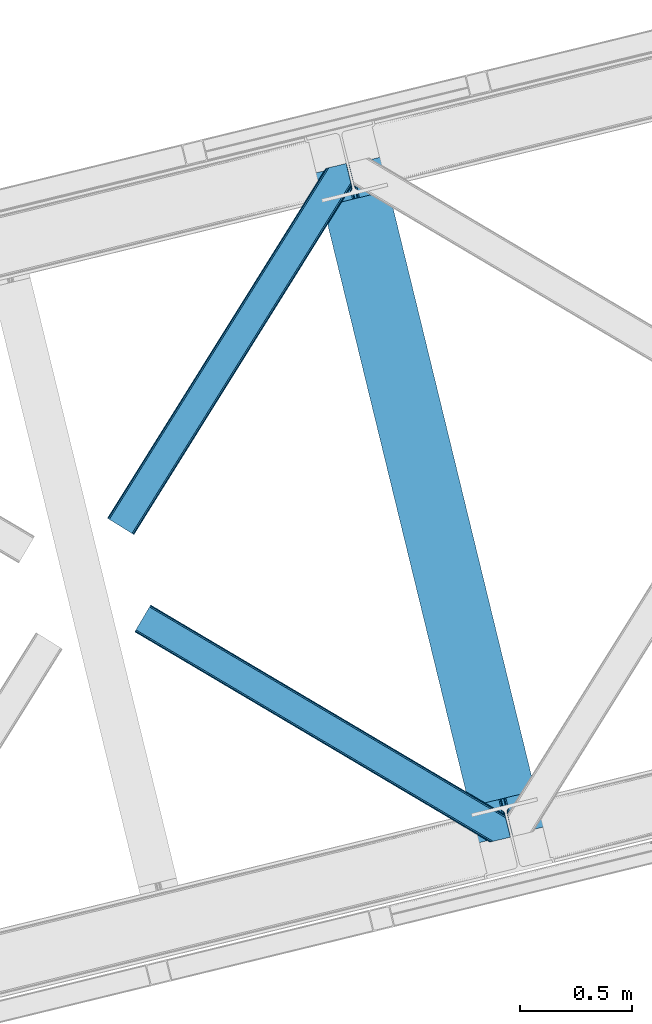
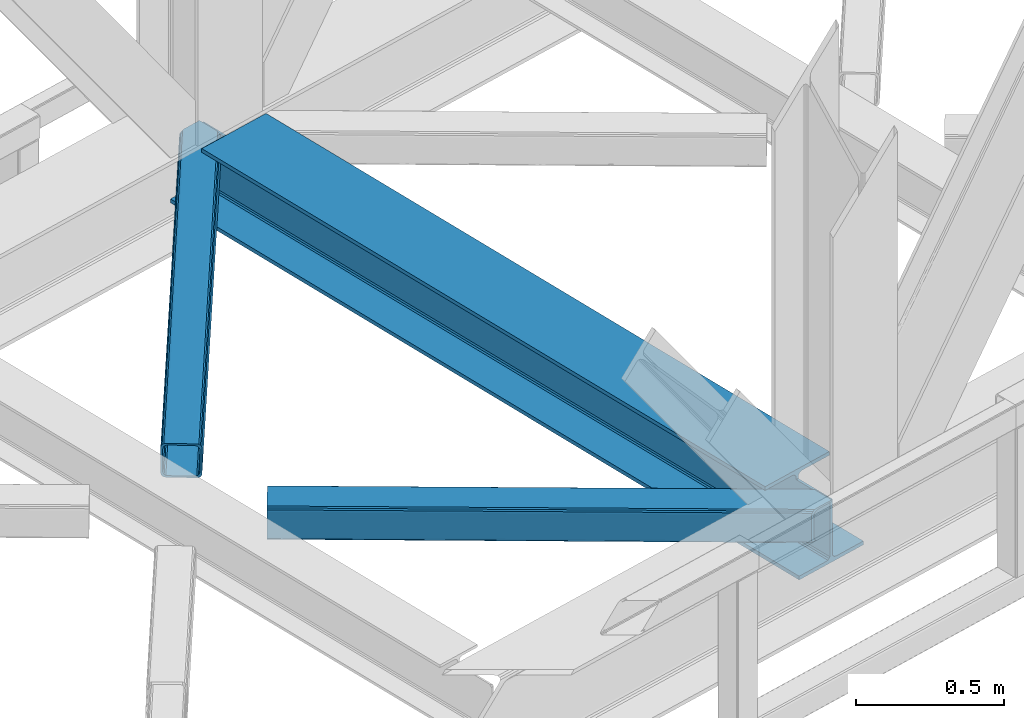
# One storey, part 67 of 92: 2 members, 1 beam.
"""IFC4 building model written with IfcOpenShell, lengths in millimetres."""

from ifc_helpers import new_model, entity, si_unit, converted_unit, derived_unit, direction, frame, origin, place, context, subcontext, project, spatial, triangles, polygons, material, type_object, element, save


model = new_model("IFC4")

# Units and contexts
model_context = context("Model", 3, precision=0.01, world=origin(), true_north=direction((6.12303176911189e-17, 1.0)))
plan_context = context("Plan", 3, precision=0.01, world=origin(), true_north=direction((6.12303176911189e-17, 1.0)))
body_context = subcontext(model_context, "Body", "Model", "MODEL_VIEW")
ifc_project = project(units=[si_unit("LENGTHUNIT", "METRE", prefix="MILLI"), si_unit("AREAUNIT", "SQUARE_METRE"), si_unit("VOLUMEUNIT", "CUBIC_METRE"), converted_unit("PLANEANGLEUNIT", "DEGREE", entity("IfcRatioMeasure", 0.0174532925199433), si_unit("PLANEANGLEUNIT", "RADIAN"), dimensions=[0, 0, 0, 0, 0, 0, 0]), si_unit("MASSUNIT", "GRAM", prefix="KILO"), derived_unit("MASSDENSITYUNIT", [(si_unit("MASSUNIT", "GRAM", prefix="KILO"), 1), (si_unit("LENGTHUNIT", "METRE"), -3)]), derived_unit("MOMENTOFINERTIAUNIT", [(si_unit("LENGTHUNIT", "METRE"), 4)]), si_unit("TIMEUNIT", "SECOND"), si_unit("FREQUENCYUNIT", "HERTZ"), si_unit("THERMODYNAMICTEMPERATUREUNIT", "DEGREE_CELSIUS"), derived_unit("THERMALTRANSMITTANCEUNIT", [(si_unit("MASSUNIT", "GRAM", prefix="KILO"), 1), (si_unit("THERMODYNAMICTEMPERATUREUNIT", "KELVIN"), -1), (si_unit("TIMEUNIT", "SECOND"), -3)]), derived_unit("VOLUMETRICFLOWRATEUNIT", [(si_unit("LENGTHUNIT", "METRE"), 3), (si_unit("TIMEUNIT", "SECOND"), -1)]), derived_unit("MASSFLOWRATEUNIT", [(si_unit("MASSUNIT", "GRAM", prefix="KILO"), 1), (si_unit("TIMEUNIT", "SECOND"), -1)]), derived_unit("ROTATIONALFREQUENCYUNIT", [(si_unit("TIMEUNIT", "SECOND"), -1)]), si_unit("ELECTRICCURRENTUNIT", "AMPERE"), si_unit("ELECTRICVOLTAGEUNIT", "VOLT"), si_unit("POWERUNIT", "WATT"), si_unit("FORCEUNIT", "NEWTON", prefix="KILO"), si_unit("ILLUMINANCEUNIT", "LUX"), si_unit("LUMINOUSFLUXUNIT", "LUMEN"), si_unit("LUMINOUSINTENSITYUNIT", "CANDELA"), derived_unit("USERDEFINED", [(si_unit("MASSUNIT", "GRAM", prefix="KILO"), -1), (si_unit("LENGTHUNIT", "METRE"), -2), (si_unit("TIMEUNIT", "SECOND"), 3), (si_unit("LUMINOUSFLUXUNIT", "LUMEN"), 1)]), derived_unit("LINEARVELOCITYUNIT", [(si_unit("LENGTHUNIT", "METRE"), 1), (si_unit("TIMEUNIT", "SECOND"), -1)]), si_unit("PRESSUREUNIT", "PASCAL"), derived_unit("USERDEFINED", [(si_unit("LENGTHUNIT", "METRE"), -2), (si_unit("MASSUNIT", "GRAM", prefix="KILO"), 1), (si_unit("TIMEUNIT", "SECOND"), -2)]), derived_unit("LINEARFORCEUNIT", [(si_unit("MASSUNIT", "GRAM", prefix="KILO"), 1), (si_unit("LENGTHUNIT", "METRE"), 1), (si_unit("TIMEUNIT", "SECOND"), -2), (si_unit("LENGTHUNIT", "METRE"), -1)]), derived_unit("PLANARFORCEUNIT", [(si_unit("MASSUNIT", "GRAM", prefix="KILO"), 1), (si_unit("LENGTHUNIT", "METRE"), 1), (si_unit("TIMEUNIT", "SECOND"), -2), (si_unit("LENGTHUNIT", "METRE"), -2)])], contexts=[model_context, plan_context])

# Site, building, storey
site_placement = place(None, origin())
site = spatial("IfcSite", under=ifc_project, at=site_placement, CompositionType="ELEMENT")
building_placement = place(site_placement, origin())
building = spatial("IfcBuilding", under=site, at=building_placement, CompositionType="ELEMENT")
storey_placement = place(building_placement, frame((0.0, 0.0, 15900.0)))
storey = spatial("IfcBuildingStorey", under=building, at=storey_placement, Name="05", CompositionType="ELEMENT", Elevation=15900.0)

# Beam
ifc_material = material(Name="Metal painted (White)")
beam_type = type_object("IfcBeamType", PredefinedType="BEAM")
beam_placement = place(storey_placement, frame((-18024.61, 13401.24, 3385.0)))
element("IfcBeam", 1, at=beam_placement, inside=storey, type_object=beam_type, material=ifc_material, ObjectType="Steel Beam", PredefinedType="BEAM", context=body_context, shape_type="Tessellation", body=[
    polygons([(1018.1664837833, 71.0478278971021, 15.4999999999986), (1018.1664837833, 71.0478278971021, 0.0), (291.465617442448, 3052.25531830422, 0.0), (291.465617442448, 3052.25531830422, 15.4999999999986), (894.779372399336, 40.9709140873291, 15.4999999999986), (168.078506058485, 3022.17840449444, 15.4999999999986), (888.087028625368, 39.3395844888221, 16.8701684148006), (161.38616228452, 3020.54707489593, 16.8701684148006), (882.413533524757, 37.956610033654, 20.7720779386413), (155.712667183904, 3019.16410044077, 20.7720779386413), (878.622625296178, 37.0325360459162, 26.6116982174316), (151.921758955327, 3018.24002645303, 26.6116982174316), (877.291435352781, 36.7080444135007, 33.500000000001), (150.59056901193, 3017.91553482062, 33.500000000001), (140.875048430516, 3015.54727389071, 33.500000000001), (140.875048430516, 3015.54727389071, 259.000000000002), (150.59056901193, 3017.91553482062, 259.000000000002), (8.66293703438714e-12, 2981.20749040711, 0.0), (6.49720277579036e-12, 2981.20749040711, 15.4999999999986), (123.38711138397, 3011.28440421689, 15.4999999999986), (130.079455157935, 3012.91573381539, 16.8701684147963), (135.752950258553, 3014.29870827056, 20.7720779386413), (139.543858487119, 3015.22278225829, 26.6116982174294), (877.291435352781, 36.7080444135007, 259.000000000002), (867.575914771367, 34.3397834835992, 259.000000000002), (867.575914771369, 34.3397834835992, 33.500000000001), (866.24472482797, 34.0152918511837, 26.6116982174294), (862.453816599404, 33.0912178634546, 20.7720779386413), (856.780321498788, 31.7082434082822, 16.8701684147963), (850.087977724821, 30.0769138097752, 15.4999999999986), (726.700866340857, 0.0, 15.4999999999986), (726.700866340857, 0.0, 0.0), (838.124523615912, 197.385937999183, 259.069791973884), (186.469722099971, 2870.72539801219, 259.000000000002), (186.693115201822, 2869.80895360721, 259.61730333112), (186.705504045448, 2869.75812937344, 266.500003008253), (837.979344808145, 197.981416001708, 266.500002998871), (837.979694928899, 197.979979696973, 260.000004007589), (828.499586345876, 194.645865944434, 259.006343171919), (828.276216326111, 195.562317481914, 259.61730333112), (828.263827482484, 195.613141715689, 266.500003008253), (176.989986719784, 2867.38985508742, 266.500002998871), (176.989636599034, 2867.39129139215, 260.000004007589), (176.844830940692, 2867.98534020594, 259.07612046749), (176.754201518561, 2868.35713708228, 259.000000000002), (839.310832678068, 198.304685446393, 273.388305639783), (843.10110926677, 199.231350618306, 279.227924098781), (848.774180214294, 200.616065081981, 283.12983240061), (855.46637189544, 202.248018612798, 284.500000377228), (978.853400583278, 232.325271667905, 284.500000138971), (978.851730776626, 232.332121736639, 299.999995328161), (687.386308679356, 161.283492472598, 299.999995890962), (687.387978486005, 161.276642403863, 284.500000701776), (810.775007173849, 191.353895458974, 284.500000463519), (817.467494070001, 192.984637925557, 283.129832461069), (823.141405718761, 194.365903570083, 279.227924137322), (826.93294050574, 195.287407219375, 273.388305663684), (175.658498849859, 2867.06658564273, 273.388305639788), (171.868222261176, 2866.13992047082, 279.227924098781), (166.195151313642, 2864.75520600715, 283.129832400619), (159.502959632499, 2863.12325247633, 284.500000377228), (36.115930944662, 2833.04599942122, 284.500000138971), (36.1176007513137, 2833.03914935249, 299.999995328161), (327.583022848584, 2904.08777861653, 299.999995890962), (327.581353041935, 2904.09462868526, 284.500000701776), (204.19432435409, 2874.01737563015, 284.500000463519), (197.501837457939, 2872.38663316357, 283.12983246106), (191.827925809187, 2871.00536751904, 279.227924137322), (188.036391022187, 2870.08386386975, 273.388305663684)], [[[1, 2, 3, 4]], [[5, 1, 4, 6]], [[7, 5, 6, 8]], [[9, 7, 8, 10]], [[11, 9, 10, 12]], [[13, 11, 12, 14]], [[15, 16, 17, 14, 12, 10, 8, 6, 4, 3, 18, 19, 20, 21, 22, 23]], [[13, 24, 25, 26, 27, 28, 29, 30, 31, 32, 2, 1, 5, 7, 9, 11]], [[2, 32, 18, 3]], [[32, 31, 19, 18]], [[31, 30, 20, 19]], [[27, 26, 15, 23]], [[28, 27, 23, 22]], [[29, 28, 22, 21]], [[30, 29, 21, 20]], [[33, 24, 13, 14, 17, 34, 35, 36, 37, 38]], [[25, 39, 40, 41, 42, 43, 44, 16, 15, 26]], [[39, 25, 24, 33]], [[45, 34, 17, 16]], [[41, 40, 38, 37, 46, 47, 48, 49, 50, 51, 52, 53, 54, 55, 56, 57]], [[42, 58, 59, 60, 61, 62, 63, 64, 65, 66, 67, 68, 69, 36, 35, 43]], [[46, 37, 36, 69]], [[47, 46, 69, 68]], [[48, 47, 68, 67]], [[49, 48, 67, 66]], [[50, 49, 66, 65]], [[51, 50, 65, 64]], [[52, 51, 64, 63]], [[53, 52, 63, 62]], [[54, 53, 62, 61]], [[55, 54, 61, 60]], [[56, 55, 60, 59]], [[57, 56, 59, 58]], [[41, 57, 58, 42]]], closed=False),
])

# Members
member_type_1 = type_object("IfcMemberType", PredefinedType="BRACE")
member_1_placement = place(storey_placement, frame((-18949.85, 14772.6, 3510.0)))
element("IfcMember", 2, at=member_1_placement, inside=storey, type_object=member_type_1, ObjectType="Steel Horizontal Brace", PredefinedType="BRACE", context=body_context, shape_type="Tessellation", body=[
    triangles([(933.016305541994, 1535.69114685059, 0.0), (967.77581176758, 1393.09054870606, 0.0), (14.8444427490249, 64.8692962646492, 0.0), (103.913424682618, 9.26687622070313, 0.0), (928.799121093751, 1552.99009094238, 5.49966430664063), (928.938647460938, 1552.41570739746, 5.20782165527635), (930.798999023438, 1544.78594055176, 1.33247680664135), (971.99299621582, 1375.79160461426, 5.49966430664063), (971.852307128906, 1376.36715087891, 5.20782165527635), (969.993118286133, 1383.99575500488, 1.33247680664135), (972.208099365234, 1375.53813171387, 5.85313110351854), (972.418551635743, 1375.28233337402, 6.20659790039281), (928.911904907229, 1553.56912536621, 5.74383544921875), (972.720858764649, 1375.53696899414, 6.35310058594041), (929.027014160158, 1554.17606506348, 5.9996337890625), (973.022003173828, 1375.79160461426, 6.49960327148438), (929.142123413087, 1554.78300476074, 6.25659484863354), (929.250256347656, 1555.36203918457, 6.49960327148438), (4.34740905761646, 71.4223846435561, 5.12526855468968), (1.13016357422021, 73.4315643310547, 10.8028289794929), (973.355703735353, 1630.84231567383, 10.8028289794929), (976.91130065918, 1631.70854187012, 6.49960327148438), (9.16455688476708, 68.4167541503921, 1.33247680664135), (971.503491210937, 1630.3900177002, 17.5000946044929), (0.0, 74.1373352050796, 17.5000946044929), (1081.09680175781, 1548.91592102051, 6.49960327148438), (1056.20297241211, 1651.03759460449, 6.49960327148438), (971.503491210937, 1630.3900177002, 122.500662231447), (0.0, 74.1373352050796, 122.500662231447), (973.355703735353, 1630.84231567383, 129.197927856447), (1.13016357422021, 73.4315643310547, 129.197927856447), (978.633288574219, 1632.12828369141, 134.874325561526), (4.34740905761646, 71.4223846435561, 134.874325561526), (986.526992797852, 1634.05258483887, 138.667117309571), (9.16455688476708, 68.4167541503921, 138.667117309571), (995.835726928712, 1636.32221374512, 139.999594116212), (14.8444427490249, 64.8692962646492, 139.999594116212), (118.757867431643, 0.0, 17.5000946044929), (117.62886657715, 0.705770874024893, 10.8028289794929), (1085.13725280762, 1551.24949951172, 10.9783996582046), (1087.41153259277, 1552.56337280274, 13.5003387451179), (109.594473266603, 5.7205810546875, 1.33247680664135), (114.410458374023, 2.71495056152344, 5.12526855468968), (1087.56501159668, 1551.93434143066, 17.5000946044929), (1081.77234191895, 1575.70149536133, 139.999594116212), (1063.00372009277, 1652.69447021484, 139.999594116212), (103.913424682618, 9.26687622070313, 139.999594116212), (1083.9896484375, 1566.60553894043, 138.667117309571), (109.594473266603, 5.7205810546875, 138.667117309571), (1085.86860351562, 1558.8955444336, 134.874325561526), (114.410458374023, 2.71495056152344, 134.874325561526), (1087.12434082031, 1553.7435333252, 129.197927856447), (117.62886657715, 0.705770874024893, 129.197927856447), (1087.56501159668, 1551.93434143066, 122.500662231447), (118.757867431643, 0.0, 122.500662231447), (1082.5362487793, 1566.77297058106, 12.1260040283232), (1083.96058044434, 1566.72297363281, 13.5003387451179), (1077.84700012207, 1569.98440246582, 8.3320495605476), (1074.64603271485, 1577.50138549805, 6.99957275390625), (1056.69131469727, 1651.1561920166, 6.99957275390625), (1005.56885375977, 1638.69416198731, 6.99957275390625), (20.7789642333992, 61.1625457763676, 6.99957275390625), (97.9742523193381, 12.9736267089847, 6.99957275390625), (108.471286010743, 6.42053833007958, 12.1260040283232), (111.689694213866, 4.41252136230469, 17.8035644531265), (1084.80704040527, 1563.24992980957, 17.8035644531265), (103.65530090332, 9.42733154296911, 8.3320495605476), (1085.24771118164, 1561.44073791504, 24.4996673583992), (112.818695068359, 3.70675048828161, 24.4996673583992), (983.088830566408, 1633.21426391602, 17.8035644531265), (981.235455322265, 1632.76312866211, 24.4996673583992), (7.06468505859448, 69.7236511230476, 17.8035644531265), (5.93568420410156, 70.4294219970707, 24.4996673583992), (988.366415405275, 1634.50139465332, 12.1260040283232), (10.283093261718, 67.7144714355472, 12.1260040283232), (996.260119628907, 1636.42569580078, 8.3320495605476), (15.0990783691414, 64.7088409423832, 8.3320495605476), (981.235455322265, 1632.76312866211, 115.501089477541), (5.93568420410156, 70.4294219970707, 115.501089477541), (996.260119628907, 1636.42569580078, 131.667544555665), (1005.56885375977, 1638.69416198731, 133.000021362306), (1063.00372009277, 1652.69447021484, 133.000021362306), (988.366415405275, 1634.50139465332, 127.87475280762), (983.088830566408, 1633.21426391602, 122.196029663086), (20.7789642333992, 61.1625457763676, 133.000021362306), (15.0990783691414, 64.7088409423832, 131.667544555665), (10.283093261718, 67.7144714355472, 127.87475280762), (7.06468505859448, 69.7236511230476, 122.196029663086), (108.471286010743, 6.42053833007958, 127.87475280762), (111.689694213866, 4.41252136230469, 122.196029663086), (112.818695068359, 3.70675048828161, 115.501089477541), (97.9742523193381, 12.9736267089847, 133.000021362306), (103.65530090332, 9.42733154296911, 131.667544555665), (1085.24771118164, 1561.44073791504, 115.501089477541), (1084.80704040527, 1563.24992980957, 122.196029663086), (1083.55130310059, 1568.40194091797, 127.87475280762), (1081.67118530273, 1576.11309814453, 131.667544555665), (1079.45504150391, 1585.2078918457, 133.000021362306)], [[1, 2, 3], [4, 3, 2], [1, 5, 2], [6, 5, 1], [1, 7, 6], [2, 5, 8], [8, 9, 2], [10, 2, 9], [11, 8, 5], [12, 11, 13], [14, 12, 15], [16, 14, 17], [17, 18, 16], [15, 17, 14], [13, 15, 12], [5, 13, 11], [17, 19, 18], [19, 17, 15], [13, 19, 15], [19, 13, 5], [5, 6, 19], [20, 21, 18], [18, 19, 20], [21, 22, 18], [19, 6, 7], [7, 1, 23], [3, 23, 1], [7, 23, 19], [24, 21, 20], [20, 25, 24], [18, 26, 16], [26, 18, 22], [27, 26, 22], [28, 24, 29], [25, 29, 24], [30, 28, 31], [29, 31, 28], [32, 30, 33], [31, 33, 30], [34, 32, 35], [33, 35, 32], [36, 34, 37], [35, 37, 34], [38, 39, 40], [40, 41, 38], [42, 10, 9], [39, 12, 16], [16, 40, 39], [16, 26, 40], [9, 39, 43], [9, 12, 39], [9, 43, 42], [2, 10, 4], [42, 4, 10], [41, 44, 38], [45, 36, 37], [36, 45, 46], [37, 47, 45], [48, 45, 47], [47, 49, 48], [50, 48, 49], [49, 51, 50], [52, 50, 51], [51, 53, 52], [54, 52, 53], [53, 55, 54], [44, 54, 38], [55, 38, 54], [56, 40, 26], [41, 40, 56], [56, 57, 41], [58, 26, 59], [26, 58, 56], [60, 59, 26], [59, 61, 62], [61, 59, 60], [62, 63, 59], [64, 65, 66], [66, 57, 64], [58, 59, 63], [63, 67, 58], [56, 58, 67], [67, 64, 56], [57, 56, 64], [68, 66, 65], [65, 69, 68], [70, 71, 72], [73, 72, 71], [74, 70, 75], [72, 75, 70], [76, 74, 77], [75, 77, 74], [61, 76, 62], [77, 62, 76], [71, 78, 79], [79, 73, 71], [34, 36, 80], [46, 81, 36], [81, 46, 82], [81, 80, 36], [83, 34, 80], [83, 32, 34], [32, 84, 30], [84, 32, 83], [28, 84, 78], [84, 28, 30], [61, 22, 76], [70, 74, 22], [74, 76, 22], [61, 60, 22], [71, 70, 24], [21, 24, 70], [28, 71, 24], [71, 28, 78], [70, 22, 21], [80, 81, 85], [85, 86, 80], [83, 80, 86], [86, 87, 83], [84, 83, 87], [87, 88, 84], [78, 84, 88], [88, 79, 78], [53, 89, 90], [91, 38, 55], [53, 90, 55], [53, 51, 89], [90, 91, 55], [89, 51, 49], [92, 47, 37], [47, 93, 49], [93, 47, 92], [93, 89, 49], [39, 64, 43], [69, 38, 91], [38, 65, 39], [65, 38, 69], [39, 65, 64], [4, 63, 3], [42, 43, 64], [64, 67, 42], [67, 63, 4], [4, 42, 67], [87, 35, 33], [37, 85, 92], [37, 86, 85], [86, 37, 35], [87, 86, 35], [79, 29, 25], [31, 88, 87], [33, 31, 87], [88, 31, 29], [79, 88, 29], [23, 75, 19], [3, 63, 62], [62, 77, 3], [77, 75, 23], [23, 3, 77], [20, 19, 75], [25, 73, 79], [72, 25, 20], [25, 72, 73], [72, 20, 75], [66, 41, 57], [54, 44, 68], [44, 66, 68], [68, 94, 54], [44, 41, 66], [95, 54, 94], [52, 54, 95], [50, 95, 96], [95, 50, 52], [96, 48, 50], [97, 48, 96], [97, 98, 45], [97, 45, 48], [98, 46, 45], [98, 82, 46], [81, 98, 85], [81, 82, 98], [92, 85, 98], [95, 94, 90], [91, 90, 94], [96, 95, 89], [90, 89, 95], [97, 96, 93], [89, 93, 96], [98, 97, 92], [93, 92, 97], [94, 68, 69], [69, 91, 94]]),
])
member_type_2 = type_object("IfcMemberType", PredefinedType="BRACE")
member_2_placement = place(storey_placement, frame((-18828.09, 13404.29, 3510.0)))
element("IfcMember", 3, at=member_2_placement, inside=storey, type_object=member_type_2, ObjectType="Steel Horizontal Brace", PredefinedType="BRACE", context=body_context, shape_type="Tessellation", body=[
    triangles([(1468.20108032227, 208.966314697265, 0.0), (1502.96174926758, 66.3657165527347, 0.0), (8.9145721435525, 950.879168701171, 0.0), (62.4054931640603, 1041.23295593262, 0.0), (0.677865600584482, 936.96722717285, 10.8028289794929), (1582.93826293945, 0.542990112304324, 10.8679412841811), (1580.71049194336, 0.0, 17.5000946044929), (1509.32066345215, 44.5019348144524, 9.52034912109593), (2.6114685058601, 940.232144165038, 5.12526855468968), (1507.05801086426, 49.5597656249993, 5.12526855468968), (1507.93353881836, 45.9669616699211, 8.52041015625218), (1508.98463745117, 44.856564331054, 9.27850341796875), (1508.63000793457, 45.2344482421868, 9.02037963867406), (1508.26956481934, 45.6123321533196, 8.76225585937573), (1583.38939819336, 0.653448486327761, 9.52034912109593), (1505.17905578613, 57.2709228515614, 1.33247680664135), (5.50315246581886, 945.116729736328, 1.33247680664135), (0.0, 935.820785522461, 17.5000946044929), (1580.71049194336, 0.0, 122.500662231447), (0.0, 935.820785522461, 122.500662231447), (1595.73399353027, 3.66256713867188, 138.667117309571), (1605.04272766113, 5.93103332519422, 139.999594116212), (8.9145721435525, 950.879168701171, 139.999594116212), (5.50315246581886, 945.116729736328, 138.667117309571), (1587.84028930664, 1.73826599121094, 134.874325561526), (2.6114685058601, 940.232144165038, 134.874325561526), (1582.56270446777, 0.451135253906614, 129.197927856447), (0.677865600584482, 936.96722717285, 129.197927856447), (1503.00593261719, 66.183169555663, 8.52041015625218), (1503.36637573242, 65.041378784179, 8.90294494629052), (1503.85704345703, 64.3216552734375, 9.10758361816625), (1504.35585021973, 63.5937927246086, 9.31571044922021), (1504.84186706543, 62.8729064941399, 9.52034912109593), (1602.19638977051, 5.23805236816406, 9.52034912109593), (9.07153930663844, 951.140780639647, 8.3320495605476), (1502.85361633301, 66.8075500488285, 8.42274169922166), (6.1786926269524, 946.255032348632, 12.1260040283232), (1597.57341613769, 4.11021423339844, 12.1260040283232), (1500.64444885254, 75.8721130371086, 6.99957275390625), (12.4817962646484, 956.903219604492, 6.99957275390625), (1592.29583129883, 2.82424621581958, 17.8035644531265), (4.24625244140407, 942.991278076172, 17.8035644531265), (1590.44361877441, 2.37311096191297, 24.4996673583992), (3.56373596191406, 941.843673706055, 24.4996673583992), (1470.5183807373, 199.458755493164, 6.99957275390625), (58.838269042968, 1035.2089050293, 6.99957275390625), (1463.22929077148, 229.365069580077, 8.52041015625218), (1468.15689697265, 209.14769897461, 8.52041015625218), (1464.10481872558, 225.771102905273, 5.12526855468968), (1468.30921325683, 208.524481201172, 8.42274169922166), (1465.98377380371, 218.061108398437, 1.33247680664135), (1590.44361877441, 2.37311096191297, 115.501089477541), (3.56373596191406, 941.843673706055, 115.501089477541), (1592.29583129883, 2.82424621581958, 122.196029663086), (4.24625244140407, 942.991278076172, 122.196029663086), (1597.57341613769, 4.11021423339844, 127.87475280762), (6.1786926269524, 946.255032348632, 127.87475280762), (1605.46712036133, 6.03451538085938, 131.667544555665), (9.07153930663844, 951.140780639647, 131.667544555665), (1614.77585449219, 8.30414428710901, 133.000021362306), (12.4817962646484, 956.903219604492, 133.000021362306), (1672.21072082519, 22.3044525146488, 139.999594116212), (1672.21072082519, 22.3044525146488, 133.000021362306), (1653.44326171875, 99.2985900878903, 139.999594116212), (62.4054931640603, 1041.23295593262, 139.999594116212), (1655.76056213379, 89.7910308837891, 133.000021362306), (58.838269042968, 1035.2089050293, 133.000021362306), (1648.09126281738, 121.255389404296, 129.197927856447), (1647.64942932129, 123.064581298828, 122.500662231447), (70.642199707032, 1055.14489746094, 129.197927856447), (71.3200653076165, 1056.29133911133, 122.500662231447), (1649.34700012207, 116.103378295898, 134.874325561526), (68.7097595214836, 1051.88114318848, 134.874325561526), (1651.2259552002, 108.393383789062, 138.667117309571), (65.8169128417976, 1046.99539489746, 138.667117309571), (1647.64942932129, 123.064581298828, 17.5000946044929), (71.3200653076165, 1056.29133911133, 17.5000946044929), (70.642199707032, 1055.14489746094, 10.8028289794929), (65.1425354003914, 1045.85709228516, 12.1260040283232), (67.074975585936, 1049.12200927734, 17.8035644531265), (67.7528411865242, 1050.26728820801, 24.4996673583992), (68.7097595214836, 1051.88114318848, 5.12526855468968), (65.8169128417976, 1046.99539489746, 1.33247680664135), (62.2496887207017, 1040.97134399414, 8.3320495605476), (65.1425354003914, 1045.85709228516, 127.87475280762), (67.7528411865242, 1050.26728820801, 115.501089477541), (67.074975585936, 1049.12200927734, 122.196029663086), (62.2496887207017, 1040.97134399414, 131.667544555665), (1649.96672973633, 113.558184814452, 24.4996673583992), (1649.96672973633, 113.558184814452, 115.501089477541), (1653.54325561523, 98.8869873046879, 131.667544555665), (1651.66430053711, 106.596981811523, 127.87475280762), (1650.40856323242, 111.748992919922, 122.196029663086), (1650.49692993164, 111.385061645507, 17.8686767578147), (1650.60390014649, 110.943228149414, 16.5199218750022), (1647.6587310791, 123.027374267578, 16.5199218750022), (1641.3730682373, 124.97144165039, 10.8702667236357), (1463.4490447998, 229.701095581055, 9.22734375000073), (1463.34091186523, 229.533663940429, 8.87387695312646), (1464.24783325195, 229.405764770507, 9.52034912109593), (1639.8673461914, 125.435366821288, 9.52034912109593), (1646.38206481934, 109.728186035156, 12.1260040283232), (1468.72662963867, 211.034793090819, 9.52034912109593), (1644.34614257812, 107.0643951416, 9.52034912109593)], [[1, 2, 3], [3, 4, 1], [5, 6, 7], [6, 5, 8], [5, 9, 10], [10, 11, 5], [12, 5, 13], [12, 8, 5], [5, 14, 13], [5, 11, 14], [8, 15, 6], [16, 10, 9], [9, 17, 16], [2, 16, 17], [17, 3, 2], [7, 18, 5], [7, 19, 20], [20, 18, 7], [21, 22, 23], [23, 24, 21], [25, 21, 24], [24, 26, 25], [27, 25, 26], [26, 28, 27], [19, 27, 28], [28, 20, 19], [11, 29, 30], [14, 30, 31], [13, 31, 32], [12, 32, 33], [33, 8, 12], [32, 12, 13], [31, 13, 14], [30, 14, 11], [34, 15, 33], [8, 33, 15], [35, 30, 29], [32, 35, 33], [35, 32, 31], [30, 35, 31], [29, 36, 35], [37, 38, 33], [33, 35, 37], [38, 34, 33], [35, 36, 39], [39, 40, 35], [41, 38, 37], [37, 42, 41], [43, 41, 42], [42, 44, 43], [39, 45, 40], [46, 40, 45], [1, 45, 39], [47, 48, 49], [48, 50, 1], [45, 1, 50], [48, 51, 49], [48, 1, 51], [2, 1, 39], [2, 39, 36], [29, 2, 36], [11, 10, 29], [29, 16, 2], [29, 10, 16], [52, 43, 44], [44, 53, 52], [54, 52, 55], [53, 55, 52], [56, 54, 57], [55, 57, 54], [58, 56, 59], [57, 59, 56], [60, 58, 61], [59, 61, 58], [56, 58, 21], [25, 56, 21], [25, 27, 54], [56, 25, 54], [54, 27, 19], [58, 22, 21], [62, 60, 63], [62, 22, 60], [58, 60, 22], [54, 19, 52], [43, 7, 41], [19, 43, 52], [7, 6, 41], [19, 7, 43], [15, 41, 6], [38, 41, 15], [34, 38, 15], [22, 64, 23], [22, 62, 64], [65, 23, 64], [66, 60, 61], [60, 66, 63], [61, 67, 66], [68, 69, 70], [71, 70, 69], [72, 68, 73], [70, 73, 68], [74, 72, 75], [73, 75, 72], [64, 74, 65], [75, 65, 74], [69, 76, 77], [77, 71, 69], [78, 79, 80], [81, 71, 77], [78, 80, 77], [78, 82, 79], [80, 81, 77], [79, 82, 83], [46, 4, 3], [4, 84, 83], [84, 4, 46], [84, 79, 83], [70, 85, 73], [86, 71, 81], [71, 87, 70], [87, 71, 86], [70, 87, 85], [65, 67, 23], [75, 73, 85], [85, 88, 75], [88, 67, 65], [65, 75, 88], [37, 17, 9], [3, 40, 46], [3, 35, 40], [35, 3, 17], [37, 35, 17], [44, 18, 20], [5, 42, 37], [9, 5, 37], [42, 5, 18], [44, 42, 18], [24, 57, 26], [23, 67, 61], [61, 59, 23], [59, 57, 24], [24, 23, 59], [28, 26, 57], [20, 53, 44], [55, 20, 28], [20, 55, 53], [55, 28, 57], [89, 90, 81], [86, 81, 90], [91, 66, 67], [67, 88, 91], [92, 91, 88], [88, 85, 92], [93, 92, 85], [85, 87, 93], [90, 93, 87], [87, 86, 90], [92, 72, 74], [66, 91, 64], [91, 92, 74], [94, 95, 96], [63, 66, 62], [64, 62, 66], [91, 74, 64], [94, 76, 89], [69, 90, 89], [89, 76, 69], [94, 96, 76], [69, 93, 90], [93, 72, 92], [72, 93, 68], [69, 68, 93], [77, 76, 97], [76, 96, 97], [98, 99, 82], [47, 82, 99], [47, 49, 82], [78, 97, 100], [100, 82, 78], [100, 98, 82], [97, 101, 100], [51, 1, 4], [4, 83, 51], [49, 51, 83], [83, 82, 49], [97, 78, 77], [80, 79, 102], [102, 95, 80], [80, 94, 89], [46, 45, 50], [103, 102, 79], [103, 104, 102], [50, 79, 84], [50, 103, 79], [50, 84, 46], [89, 81, 80], [95, 94, 80], [96, 102, 97], [102, 96, 95], [102, 101, 97], [102, 104, 101], [101, 104, 103], [103, 100, 101]]),
])

save(model, "model.ifc")
